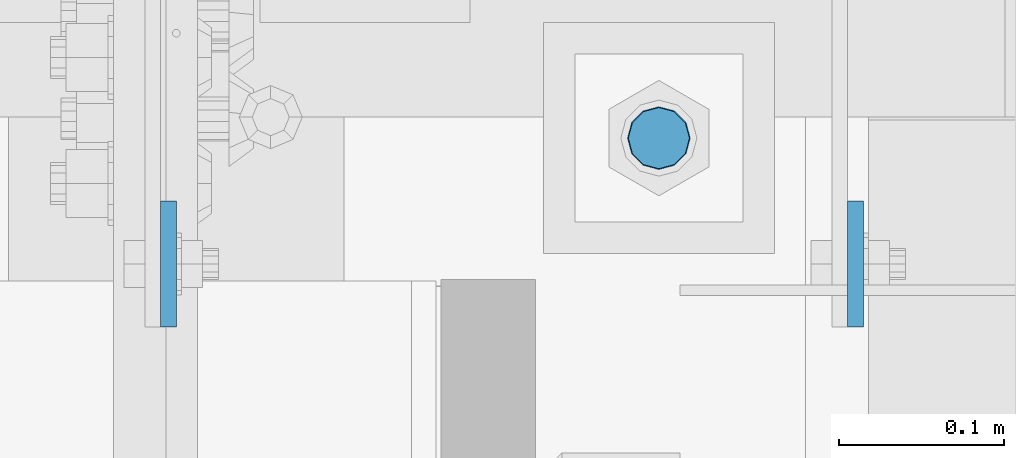
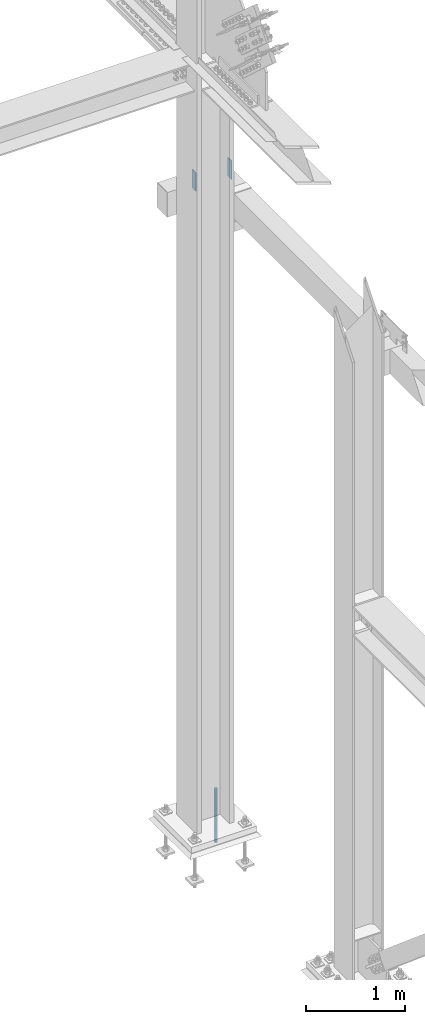
# One storey, part 1621 of 3843: 3 columns, 3 elements without a shape of their own.
"""IFC2X3 building model written with IfcOpenShell, lengths in millimetres."""

from ifc_helpers import new_model, si_unit, frame, origin_with_axes, place, context, subcontext, project, spatial, faceted_brep, material, type_object, element, aggregate, save


model = new_model("IFC2X3")

# Units and contexts
model_context = context("Model", 3, precision=1e-05, world=origin_with_axes())
body_context = subcontext(model_context, "Body", "Model", "MODEL_VIEW")
ifc_project = project(units=[si_unit("LENGTHUNIT", "METRE", prefix="MILLI"), si_unit("AREAUNIT", "SQUARE_METRE"), si_unit("VOLUMEUNIT", "CUBIC_METRE"), si_unit("MASSUNIT", "GRAM", prefix="KILO"), si_unit("TIMEUNIT", "SECOND"), si_unit("PLANEANGLEUNIT", "RADIAN"), si_unit("SOLIDANGLEUNIT", "STERADIAN"), si_unit("THERMODYNAMICTEMPERATUREUNIT", "DEGREE_CELSIUS"), si_unit("LUMINOUSINTENSITYUNIT", "LUMEN")], contexts=[model_context])

# Site, building, storey
site_placement = place(None, origin_with_axes())
site = spatial("IfcSite", under=ifc_project, at=site_placement, CompositionType="ELEMENT")
building_placement = place(site_placement, origin_with_axes())
building = spatial("IfcBuilding", under=site, at=building_placement, Name="Undefined", CompositionType="ELEMENT")
storey_placement = place(building_placement, origin_with_axes())
storey = spatial("IfcBuildingStorey", under=building, at=storey_placement, Name="Undefined", CompositionType="ELEMENT", Elevation=0.0)

# Assembly, column
assembly_1_placement = place(storey_placement, origin_with_axes())
assembly_1 = element("IfcElementAssembly", 1, at=assembly_1_placement, inside=storey, Name="COLUMN", AssemblyPlace="NOTDEFINED", PredefinedType="RIGID_FRAME")
ifc_material_1 = material(Name="STEEL/A572-50")
column_type_1 = type_object("IfcColumnType", PredefinedType="NOTDEFINED")
column_1_placement = place(assembly_1_placement, frame((85644.0375, 28930.6, 37744.4), z_axis=(0.0, 1.0, 0.0), x_axis=(0.0, 0.0, 1.0)))
column_1 = element("IfcColumn", 2, at=column_1_placement, type_object=column_type_1, material=ifc_material_1, Name="PLATE", context=body_context, shape_type="Brep", body=[
    faceted_brep([(0.0, 4.76250000000073, -38.0999999999985), (0.0, 4.76250000000073, 38.0999999999985), (228.599999999999, 4.76249999999709, 38.1000000000058), (228.599999999999, 4.76249999999709, -38.1000000000058), (0.0, -4.76250000000073, 38.0999999999985), (228.599999999999, -4.76249999999709, 38.1000000000058), (0.0, -4.76250000000073, -38.0999999999985), (228.599999999999, -4.76249999999709, -38.1000000000058)], [[[0, 1, 2, 3]], [[1, 4, 5, 2]], [[4, 6, 7, 5]], [[6, 0, 3, 7]], [[5, 7, 3, 2]], [[6, 4, 1, 0]]]),
])
aggregate(assembly_1, [column_1])

assembly_2_placement = place(storey_placement, origin_with_axes())
assembly_2 = element("IfcElementAssembly", 3, at=assembly_2_placement, inside=storey, Name="GIRT", AssemblyPlace="NOTDEFINED", PredefinedType="RIGID_FRAME")
column_2_placement = place(assembly_2_placement, frame((86059.9625, 28930.6, 37744.4), z_axis=(0.0, 1.0, 0.0), x_axis=(0.0, 0.0, 1.0)))
column_2 = element("IfcColumn", 4, at=column_2_placement, type_object=column_type_1, material=ifc_material_1, Name="PLATE", context=body_context, shape_type="Brep", body=[
    faceted_brep([(0.0, 4.76250000000073, -38.0999999999985), (0.0, 4.76250000000073, 38.0999999999985), (228.599999999999, 4.76249999999709, 38.1000000000058), (228.599999999999, 4.76249999999709, -38.1000000000058), (0.0, -4.76250000000073, 38.0999999999985), (228.599999999999, -4.76249999999709, 38.1000000000058), (0.0, -4.76250000000073, -38.0999999999985), (228.599999999999, -4.76249999999709, -38.1000000000058)], [[[0, 1, 2, 3]], [[1, 4, 5, 2]], [[4, 6, 7, 5]], [[6, 0, 3, 7]], [[5, 7, 3, 2]], [[6, 4, 1, 0]]]),
])
aggregate(assembly_2, [column_2])

assembly_3_placement = place(storey_placement, origin_with_axes())
assembly_3 = element("IfcElementAssembly", 5, at=assembly_3_placement, inside=storey, Name="TEMPLATE", AssemblyPlace="NOTDEFINED", PredefinedType="RIGID_FRAME")
ifc_material_2 = material(Name="Undefined/F1554-GR.55")
column_type_2 = type_object("IfcColumnType", PredefinedType="NOTDEFINED")
column_3_placement = place(assembly_3_placement, frame((85940.9, 29006.8, 30022.8), z_axis=(-1.0, 0.0, 0.0), x_axis=(0.0, 0.0, -1.0)))
column_3 = element("IfcColumn", 6, at=column_3_placement, type_object=column_type_2, material=ifc_material_2, Name="ANCHOR_ROD", context=body_context, shape_type="Brep", body=[
    faceted_brep([(-203.200000000001, -16.0214699700118, 9.25), (-203.200000000001, -9.25, 16.0214699700155), (-203.200000000001, 0.0, 18.5), (-203.200000000001, 9.25, 16.0214699700155), (-203.200000000001, 16.0214699700118, 9.25), (-203.200000000001, 18.5, 0.0), (-203.200000000001, 16.0214699700118, -9.25), (-203.200000000001, 9.25, -16.0214699700155), (-203.200000000001, 0.0, -18.5), (-203.200000000001, -9.25, -16.0214699700155), (-203.200000000001, -16.0214699700118, -9.25), (-203.200000000001, -18.5, 0.0), (0.0, 18.5, 0.0), (0.0, 16.0214699700118, -9.25), (0.0, 9.25, -16.0214699700155), (0.0, 0.0, -18.5), (0.0, -9.25, -16.0214699700155), (0.0, -16.0214699700118, -9.25), (0.0, -18.5, 0.0), (0.0, -16.0214699700118, 9.25), (0.0, -9.25, 16.0214699700155), (0.0, 0.0, 18.5), (0.0, 9.25, 16.0214699700155), (0.0, 16.0214699700118, 9.25), (0.0, -16.4977839420972, 9.52500000000146), (0.0, -9.52500000000146, 16.4977839420972), (0.0, 0.0, 19.0499989999989), (0.0, 9.52500000000146, 16.4977839420972), (0.0, 16.4977839420972, 9.52500000000146), (0.0, 19.0500000000029, 0.0), (0.0, 16.4977839420972, -9.52500000000146), (0.0, 9.52500000000146, -16.4977839420972), (0.0, 0.0, -19.0499989999989), (0.0, -9.52500000000146, -16.4977839420972), (0.0, -16.4977839420972, -9.52500000000146), (0.0, -19.0500000000029, 0.0), (304.799999999999, -19.0499999999993, 0.0), (304.799999999999, -16.4977839420935, 9.52499999999418), (304.799999999999, -9.52500000000146, 16.4977839420899), (304.799987999999, 0.0, 19.0499989999989), (304.799999999999, 9.52500000000146, 16.4977839420899), (304.799999999999, 16.4977839420935, 9.52499999999418), (304.799987792969, 19.0499999999993, 0.0), (304.799999999999, 16.4977839420935, -9.52499999999418), (304.799999999999, 9.52500000000146, -16.4977839420899), (304.799987999999, 0.0, -19.0499989999989), (304.799999999999, -9.52500000000146, -16.4977839420899), (304.799999999999, -16.4977839420935, -9.52499999999418), (304.799999999999, -9.25, 16.0214699700155), (304.799999999999, 0.0, 18.5), (304.799999999999, 9.25, 16.0214699700155), (304.799999999999, 16.0214699700118, 9.25), (304.799999999999, 18.5, 0.0), (304.799999999999, 16.0214699700118, -9.25), (304.799999999999, 9.25, -16.0214699700155), (304.799999999999, 0.0, -18.5), (304.799999999999, -9.25, -16.0214699700155), (304.799999999999, -16.0214699700118, -9.25), (304.799999999999, -18.5, 0.0), (304.799999999999, -16.0214699700118, 9.25), (457.200000000001, -9.25, -16.0214699700155), (457.200000000001, 0.0, -18.5), (457.200000000001, 9.25, -16.0214699700155), (457.200000000001, 16.0214699700118, -9.25), (457.200000000001, 18.5, 0.0), (457.200000000001, 16.0214699700118, 9.25), (457.200000000001, 9.25, 16.0214699700155), (457.200000000001, 0.0, 18.5), (457.200000000001, -9.25, 16.0214699700155), (457.200000000001, -16.0214699700118, 9.25), (457.200000000001, -18.5, 0.0), (457.200000000001, -16.0214699700118, -9.25)], [[[0, 1, 2, 3, 4, 5, 6, 7, 8, 9, 10, 11]], [[6, 5, 12, 13]], [[7, 6, 13, 14]], [[8, 7, 14, 15]], [[9, 8, 15, 16]], [[10, 9, 16, 17]], [[11, 10, 17, 18]], [[0, 11, 18, 19]], [[1, 0, 19, 20]], [[2, 1, 20, 21]], [[3, 2, 21, 22]], [[4, 3, 22, 23]], [[5, 4, 23, 12]], [[24, 25, 26, 27, 28, 29, 30, 31, 32, 33, 34, 35], [22, 21, 20, 19, 18, 17, 16, 15, 14, 13, 12, 23]], [[24, 35, 36, 37]], [[25, 24, 37, 38]], [[26, 25, 38, 39]], [[27, 26, 39, 40]], [[28, 27, 40, 41]], [[29, 28, 41, 42]], [[30, 29, 42, 43]], [[31, 30, 43, 44]], [[32, 31, 44, 45]], [[33, 32, 45, 46]], [[34, 33, 46, 47]], [[35, 34, 47, 36]], [[46, 45, 44, 43, 42, 41, 40, 39, 38, 37, 36, 47], [48, 49, 50, 51, 52, 53, 54, 55, 56, 57, 58, 59]], [[60, 61, 62, 63, 64, 65, 66, 67, 68, 69, 70, 71]], [[68, 67, 49, 48]], [[69, 68, 48, 59]], [[70, 69, 59, 58]], [[71, 70, 58, 57]], [[60, 71, 57, 56]], [[61, 60, 56, 55]], [[62, 61, 55, 54]], [[63, 62, 54, 53]], [[64, 63, 53, 52]], [[65, 64, 52, 51]], [[66, 65, 51, 50]], [[67, 66, 50, 49]]]),
])
aggregate(assembly_3, [column_3])

save(model, "model.ifc")
